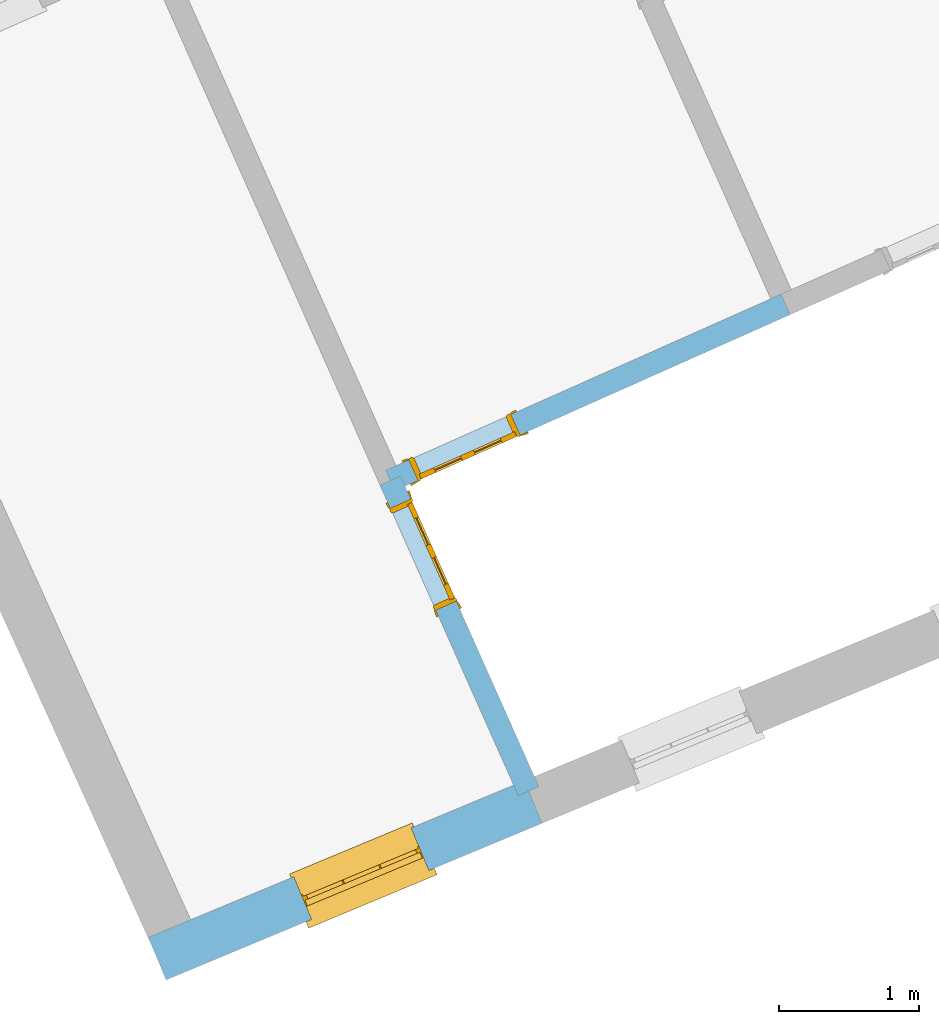
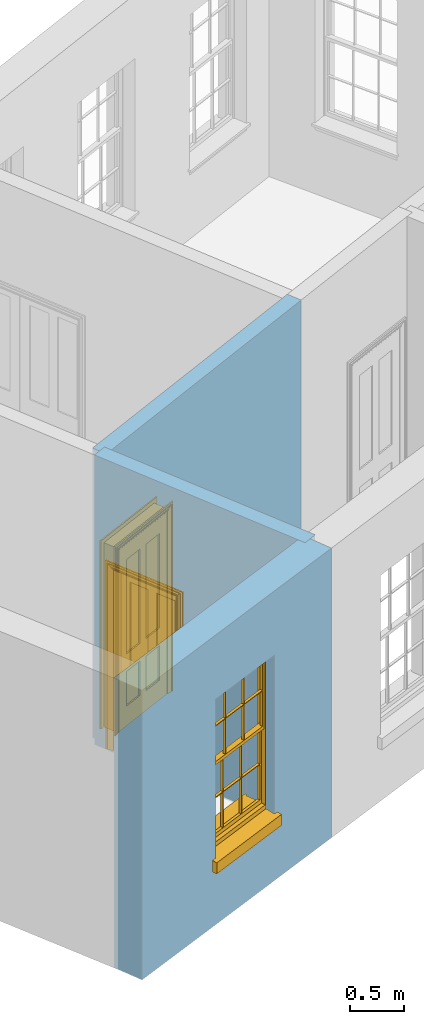
# One storey, part 2 of 8: 2 doors, 1 window, 3 openings, plus 3 elements that do not belong to this part.
"""IFC2X3 building model written with IfcOpenShell, lengths in metres."""

from ifc_helpers import new_model, si_unit, frame, origin, place, context, subcontext, project, spatial, polyline, outline, extrude, faceted_brep, material, layer, layer_set, layer_usage, element, fill, save


model = new_model("IFC2X3")

# Units and contexts
model_context = context("Model", 3, world=origin())
body_context = subcontext(model_context, "Body", "Model", "MODEL_VIEW")
ifc_project = project(units=[si_unit("PLANEANGLEUNIT", "RADIAN"), si_unit("MASSUNIT", "GRAM", prefix="KILO"), si_unit("FORCEUNIT", "NEWTON", prefix="KILO"), si_unit("LENGTHUNIT", "METRE")], contexts=[model_context])

# Site, building, storey
site_placement = place(None, origin())
site = spatial("IfcSite", under=ifc_project, at=site_placement, CompositionType="ELEMENT")
building_placement = place(None, origin())
building = spatial("IfcBuilding", under=site, at=building_placement, Name="Building plot-1", CompositionType="ELEMENT")
storey_placement = place(None, frame((0.0, 0.0, 5.15)))
storey = spatial("IfcBuildingStorey", under=building, at=storey_placement, Name="Floor 1", CompositionType="ELEMENT", Elevation=5.15)

# Wall, opening, window
ifc_material_1 = material(Name="Masonry")
ifc_layer_1 = layer(ifc_material_1, 0.33, ventilated=False)
ifc_layer_set_1 = layer_set([ifc_layer_1], Name="My Wall")
ifc_layer_usage_1 = layer_usage(ifc_layer_set_1, "AXIS2", "NEGATIVE", 0.08)
wall_1_placement = place(storey_placement, origin())
wall_1 = element("IfcWallStandardCase", 1, at=wall_1_placement, inside=storey, material=ifc_layer_usage_1, Name="exterior", context=body_context, shape_type="SweptSolid", body=[
    extrude(outline(polyline([(21.5557040167118, 40.2736905266135), (21.6826157364214, 39.9690704100743), (24.3699915253352, 41.0886927342715), (24.2430798056257, 41.3933128508107), (21.5557040167118, 40.2736905266135)])), origin(), (0.0, 0.0, 1.0), 3.3),
])
opening_1_placement = place(storey_placement, frame((0.0, 0.0, 0.75)))
opening_1 = element("IfcOpeningElement", 2, at=opening_1_placement, cuts=wall_1, Name="Opening", ObjectType="Opening", context=body_context, shape_type="SweptSolid", body=[
    extrude(outline(polyline([(22.7216835143391, 40.4019698524633), (23.5616965629775, 40.7519385340866), (23.434784843268, 41.0565586506259), (22.5947717946295, 40.7065899690026), (22.7216835143391, 40.4019698524633)])), origin(), (0.0, 0.0, 1.0), 1.82),
])
window_placement = place(storey_placement, frame((22.6255382721349, 40.6327426680233, 0.75), z_axis=(0.0, 0.0, 1.0), x_axis=(0.840013048638443, 0.349968681623302, 0.0)))
window = element("IfcWindow", 3, at=window_placement, inside=storey, Name="bedroom outside window", OverallHeight=1.82, OverallWidth=0.91, context=body_context, shape_type="Brep", held_by="IfcProductRepresentation", body=[
    faceted_brep([(0.033125, -0.105, 0.975209), (0.01, -0.105, 0.975209), (0.033125, -0.105, 1.376042), (0.876875, -0.105, 0.975209), (0.876875, -0.105, 1.376042), (0.9, -0.105, 0.975209), (0.876875, -0.105, 1.386042), (0.876875, -0.105, 1.786875), (0.9, -0.105, 1.81), (0.033125, -0.105, 1.786875), (0.033125, -0.105, 1.386042), (0.01, -0.105, 1.81), (0.876875, -0.135, 1.376042), (0.876875, -0.135, 0.975209), (0.9, -0.135, 0.937083), (0.033125, -0.135, 1.786875), (0.01, -0.135, 1.81), (0.033125, -0.135, 1.386042), (0.01, -0.135, 0.937083), (0.033125, -0.135, 0.975209), (0.033125, -0.135, 1.376042), (0.876875, -0.135, 1.786875), (0.876875, -0.135, 1.386042), (0.9, -0.135, 1.81), (0.033125, -0.105, 0.937083), (0.01, -0.105, 0.937083), (0.033125, -0.105, 0.53625), (0.876875, -0.105, 0.937083), (0.876875, -0.105, 0.53625), (0.9, -0.105, 0.937083), (0.876875, -0.105, 0.52625), (0.876875, -0.105, 0.125417), (0.9, -0.105, 0.077167), (0.033125, -0.105, 0.125417), (0.033125, -0.105, 0.52625), (0.01, -0.105, 0.077167), (-0.0425, -0.25, 0.01), (-0.0425, -0.3, 0.001667), (0.0, -0.25, 0.01), (0.9525, -0.25, 0.01), (0.91, -0.25, 0.01), (0.9525, -0.3, 0.001667), (-0.02, 0.08, 0.077167), (0.0, 0.08, 0.077167), (-0.02, 0.11, 0.077167), (0.0, -0.06, 0.077167), (0.01, -0.06, 0.077167), (0.91, -0.06, 0.077167), (0.91, 0.08, 0.077167), (0.9, -0.06, 0.077167), (0.93, 0.08, 0.077167), (0.93, 0.11, 0.077167), (0.01, -0.075, 0.975209), (0.9, -0.075, 0.975209), (0.876875, -0.075, 0.125417), (0.876875, -0.075, 0.52625), (0.9, -0.075, 0.077167), (0.876875, -0.075, 0.53625), (0.876875, -0.075, 0.937083), (0.033125, -0.075, 0.125417), (0.01, -0.075, 0.077167), (0.033125, -0.075, 0.52625), (0.033125, -0.075, 0.937083), (0.033125, -0.075, 0.53625), (-0.02, 0.08, 0.052167), (-0.02, 0.11, 0.052167), (0.93, 0.11, 0.052167), (0.93, 0.08, 0.052167), (0.91, 0.08, 0.052167), (0.0, 0.08, 0.052167), (0.91, -0.15, 0.026667), (0.0, -0.15, 0.026667), (-0.0425, -0.3, -0.123333), (0.9525, -0.3, -0.123333), (-0.0425, -0.25, -0.123333), (0.9525, -0.25, -0.123333), (0.01, -0.06, 1.81), (0.9, -0.06, 1.81), (0.0, -0.06, 1.82), (0.91, -0.06, 1.82), (0.01, -0.15, 0.077167), (0.9, -0.15, 0.077167), (0.592292, -0.105, 0.125417), (0.592292, -0.075, 0.125417), (0.317708, -0.075, 0.125417), (0.317708, -0.105, 0.125417), (0.592292, -0.105, 0.53625), (0.317708, -0.105, 0.53625), (0.317708, -0.105, 0.52625), (0.592292, -0.105, 0.52625), (0.592292, -0.075, 0.53625), (0.317708, -0.075, 0.53625), (0.592292, -0.135, 1.386042), (0.592292, -0.105, 1.386042), (0.317708, -0.105, 1.386042), (0.317708, -0.135, 1.386042), (0.317708, -0.135, 1.376042), (0.592292, -0.135, 1.376042), (0.317708, -0.105, 1.376042), (0.592292, -0.105, 1.376042), (0.602292, -0.135, 1.376042), (0.592292, -0.135, 0.975209), (0.602292, -0.135, 0.975209), (0.602292, -0.105, 0.975209), (0.592292, -0.105, 0.975209), (0.602292, -0.105, 1.376042), (0.602292, -0.075, 0.53625), (0.602292, -0.105, 0.53625), (0.317708, -0.075, 0.52625), (0.307708, -0.075, 0.125417), (0.307708, -0.075, 0.52625), (0.602292, -0.075, 0.52625), (0.602292, -0.075, 0.125417), (0.592292, -0.075, 0.52625), (0.307708, -0.075, 0.53625), (0.317708, -0.075, 0.937083), (0.307708, -0.075, 0.937083), (0.602292, -0.075, 0.937083), (0.592292, -0.075, 0.937083), (0.307708, -0.105, 0.52625), (0.307708, -0.105, 0.125417), (0.307708, -0.105, 0.53625), (0.307708, -0.105, 0.937083), (0.592292, -0.105, 0.937083), (0.317708, -0.105, 0.937083), (0.602292, -0.105, 0.937083), (0.602292, -0.105, 0.52625), (0.602292, -0.105, 0.125417), (0.307708, -0.135, 1.386042), (0.307708, -0.135, 1.376042), (0.307708, -0.135, 0.975209), (0.317708, -0.135, 0.975209), (0.317708, -0.135, 1.786875), (0.307708, -0.135, 1.786875), (0.602292, -0.135, 1.786875), (0.592292, -0.135, 1.786875), (0.602292, -0.135, 1.386042), (0.602292, -0.105, 1.386042), (0.307708, -0.105, 1.386042), (0.307708, -0.105, 1.786875), (0.317708, -0.105, 1.786875), (0.592292, -0.105, 1.786875), (0.602292, -0.105, 1.786875), (0.307708, -0.105, 1.376042), (0.317708, -0.105, 0.975209), (0.307708, -0.105, 0.975209), (0.91, -0.15, 1.82), (0.9, -0.15, 1.81), (0.01, -0.15, 1.81), (0.0, -0.15, 1.82), (0.91, -0.25, 0.0), (0.0, -0.25, 0.0), (0.91, 0.08, 0.0), (0.0, 0.08, 0.0)], [[[0, 1, 2]], [[3, 4, 5]], [[6, 7, 8]], [[9, 10, 11]], [[12, 13, 14]], [[15, 16, 17]], [[18, 19, 20]], [[21, 22, 23]], [[24, 25, 26]], [[27, 28, 29]], [[30, 31, 32]], [[33, 34, 35]], [[14, 27, 29]], [[25, 24, 18]], [[36, 37, 38]], [[39, 40, 41]], [[42, 43, 44]], [[45, 46, 43]], [[47, 48, 49]], [[50, 51, 48]], [[1, 0, 52]], [[5, 53, 3]], [[54, 55, 56]], [[57, 58, 53]], [[59, 60, 61]], [[62, 63, 52]], [[48, 43, 46, 49]], [[51, 44, 43, 48]], [[64, 42, 44, 65]], [[65, 44, 51, 66]], [[66, 51, 50, 67]], [[65, 66, 68, 69]], [[60, 56, 49, 46]], [[70, 71, 38, 40]], [[37, 41, 40, 38]], [[37, 72, 73, 41]], [[74, 75, 73, 72]], [[8, 11, 76, 77]], [[76, 78, 79, 77]], [[32, 35, 80, 81]], [[81, 80, 71, 70]], [[82, 83, 84, 85]], [[86, 87, 88, 89]], [[86, 90, 91, 87]], [[92, 93, 94, 95]], [[92, 95, 96, 97]], [[96, 98, 99, 97]], [[100, 97, 101, 102]], [[103, 104, 99, 105]], [[97, 99, 104, 101]], [[102, 103, 105, 100]], [[28, 57, 106, 107]], [[108, 84, 109, 110]], [[111, 112, 83, 113]], [[114, 110, 61, 63]], [[90, 113, 108, 91]], [[115, 91, 114, 116]], [[117, 106, 90, 118]], [[111, 106, 57, 55]], [[119, 110, 109, 120]], [[34, 61, 110, 119]], [[89, 113, 83, 82]], [[88, 108, 113, 89]], [[85, 84, 108, 88]], [[121, 114, 63, 26]], [[122, 116, 114, 121]], [[123, 118, 90, 86]], [[87, 91, 115, 124]], [[107, 106, 117, 125]], [[126, 111, 55, 30]], [[127, 112, 111, 126]], [[126, 30, 28, 107]], [[88, 119, 120, 85]], [[126, 89, 82, 127]], [[125, 123, 86, 107]], [[121, 26, 34, 119]], [[124, 122, 121, 87]], [[128, 17, 20, 129]], [[96, 129, 130, 131]], [[132, 133, 128, 95]], [[134, 135, 92, 136]], [[100, 12, 22, 136]], [[137, 6, 4, 105]], [[94, 138, 139, 140]], [[137, 93, 141, 142]], [[99, 98, 94, 93]], [[143, 2, 10, 138]], [[144, 145, 143, 98]], [[129, 143, 145, 130]], [[20, 2, 143, 129]], [[131, 144, 98, 96]], [[128, 138, 10, 17]], [[133, 139, 138, 128]], [[135, 141, 93, 92]], [[95, 94, 140, 132]], [[22, 6, 137, 136]], [[136, 137, 142, 134]], [[100, 105, 4, 12]], [[107, 86, 89, 126]], [[106, 111, 113, 90]], [[91, 108, 110, 114]], [[87, 121, 119, 88]], [[97, 100, 136, 92]], [[129, 96, 95, 128]], [[98, 143, 138, 94]], [[105, 99, 93, 137]], [[131, 101, 104, 144]], [[124, 115, 118, 123]], [[132, 140, 141, 135]], [[120, 109, 59, 33]], [[15, 9, 139, 133]], [[134, 142, 7, 21]], [[31, 54, 112, 127]], [[36, 74, 72, 37]], [[39, 41, 73, 75]], [[18, 14, 101, 131]], [[23, 16, 132, 135]], [[83, 56, 60, 84]], [[52, 53, 118, 115]], [[53, 52, 144, 104]], [[11, 8, 141, 140]], [[14, 18, 124, 123]], [[2, 1, 11, 10]], [[8, 5, 4, 6]], [[57, 53, 56, 55]], [[60, 52, 63, 61]], [[26, 25, 35, 34]], [[32, 29, 28, 30]], [[14, 23, 22, 12]], [[18, 20, 17, 16]], [[19, 0, 2, 20]], [[17, 10, 9, 15]], [[12, 4, 3, 13]], [[21, 7, 6, 22]], [[27, 58, 57, 28]], [[30, 55, 54, 31]], [[33, 59, 61, 34]], [[26, 63, 62, 24]], [[5, 8, 77, 53]], [[76, 11, 1, 52]], [[46, 45, 78, 76]], [[49, 77, 79, 47]], [[70, 146, 147, 81]], [[71, 80, 148, 149]], [[19, 130, 145, 0]], [[102, 13, 3, 103]], [[116, 122, 24, 62]], [[29, 32, 81, 14]], [[80, 35, 25, 18]], [[60, 46, 76, 52]], [[77, 49, 56, 53]], [[23, 14, 81, 147]], [[16, 148, 80, 18]], [[35, 85, 120]], [[120, 33, 35]], [[127, 82, 32]], [[32, 31, 127]], [[32, 82, 85, 35]], [[102, 101, 14]], [[14, 13, 102]], [[18, 131, 130]], [[130, 19, 18]], [[134, 21, 23]], [[23, 135, 134]], [[16, 15, 133]], [[133, 132, 16]], [[11, 140, 139]], [[139, 9, 11]], [[142, 141, 8]], [[8, 7, 142]], [[23, 147, 148, 16]], [[146, 149, 148, 147]], [[52, 115, 116]], [[116, 62, 52]], [[118, 53, 117]], [[58, 117, 53]], [[27, 125, 117, 58]], [[56, 83, 112]], [[112, 54, 56]], [[109, 84, 60]], [[60, 59, 109]], [[125, 27, 14]], [[14, 123, 125]], [[122, 124, 18]], [[18, 24, 122]], [[145, 144, 52]], [[52, 0, 145]], [[103, 3, 53]], [[53, 104, 103]], [[79, 78, 149, 146]], [[78, 45, 71, 149]], [[146, 70, 47, 79]], [[150, 75, 74, 151]], [[68, 66, 67]], [[48, 68, 67, 50]], [[69, 64, 65]], [[42, 64, 69, 43]], [[69, 68, 152, 153]], [[70, 68, 48, 47]], [[150, 152, 68, 70]], [[43, 69, 71, 45]], [[69, 153, 151, 71]], [[152, 150, 151, 153]], [[38, 151, 74, 36]], [[71, 151, 38]], [[39, 75, 150, 40]], [[40, 150, 70]]]),
])
fill(opening_1, window)

# Wall, opening, door
ifc_material_2 = material(Name="Masonry")
ifc_layer_2 = layer(ifc_material_2, 0.16, ventilated=False)
ifc_layer_set_2 = layer_set([ifc_layer_2], Name="My Wall")
ifc_layer_usage_2 = layer_usage(ifc_layer_set_2, "AXIS2", "NEGATIVE", 0.08)
wall_2_placement = place(storey_placement, origin())
wall_2 = element("IfcWallStandardCase", 4, at=wall_2_placement, inside=storey, material=ifc_layer_usage_2, Name="interior", context=body_context, shape_type="SweptSolid", body=[
    extrude(outline(polyline([(23.3583541885495, 43.5717500398352), (23.2121937993953, 43.5066567172722), (24.2007660885539, 41.28691888855), (24.3469264777081, 41.352012211113), (23.3583541885495, 43.5717500398352)])), origin(), (0.0, 0.0, 1.0), 3.3),
])
opening_2_placement = place(storey_placement, frame((0.0, 0.0, 0.0199999999999996)))
opening_2 = element("IfcOpeningElement", 5, at=opening_2_placement, cuts=wall_2, Name="Opening", ObjectType="Opening", context=body_context, shape_type="SweptSolid", body=[
    extrude(outline(polyline([(23.2854237872788, 43.3422262794737), (23.6108904000941, 42.6114243337028), (23.7570507892483, 42.6765176562659), (23.4315841764329, 43.4073196020368), (23.2854237872788, 43.3422262794737)])), origin(), (0.0, 0.0, 1.0), 2.1),
])
door_1_placement = place(storey_placement, frame((23.3585039818559, 43.3747729407552, 0.0199999999999996), z_axis=(0.0, 0.0, 1.0), x_axis=(0.325466612815337, -0.730801945770885, 0.0)))
door_1 = element("IfcDoor", 6, at=door_1_placement, inside=storey, Name="bedroom inside door", OverallHeight=2.1, OverallWidth=0.8, context=body_context, shape_type="Brep", held_by="IfcProductRepresentation", body=[
    faceted_brep([(0.773, 0.08, 1.895), (0.66, 0.08, 1.895), (0.66, 0.08, 2.073), (0.773, 0.08, 2.073), (0.773, 0.08, 0.82), (0.66, 0.08, 0.82), (0.45, 0.08, 1.895), (0.45, 0.08, 2.073), (0.773, 0.08, 0.62), (0.66, 0.08, 0.62), (0.66, 0.065, 0.82), (0.66, 0.065, 1.895), (0.45, 0.065, 1.895), (0.35, 0.08, 1.895), (0.35, 0.08, 2.073), (0.773, 0.08, 0.225), (0.66, 0.08, 0.225), (0.45, 0.08, 0.62), (0.45, 0.08, 0.82), (0.45, 0.065, 0.82), (0.35, 0.08, 0.82), (0.14, 0.08, 2.073), (0.14, 0.08, 1.895), (0.773, 0.08, 0.0), (0.66, 0.08, 0.0), (0.66, 0.065, 0.225), (0.66, 0.065, 0.62), (0.45, 0.065, 0.62), (0.35, 0.08, 0.62), (0.35, 0.065, 0.82), (0.35, 0.065, 1.895), (0.14, 0.065, 1.895), (0.027, 0.08, 2.073), (0.027, 0.08, 1.895), (0.773, 0.042, 0.0), (0.66, 0.042, 0.0), (0.45, 0.08, 0.0), (0.45, 0.08, 0.225), (0.45, 0.065, 0.225), (0.35, 0.08, 0.225), (0.14, 0.08, 0.82), (0.14, 0.08, 0.62), (0.14, 0.065, 0.82), (0.027, 0.08, 0.82), (0.773, 0.042, 0.225), (0.66, 0.042, 0.225), (0.45, 0.042, 0.0), (0.35, 0.08, 0.0), (0.35, 0.065, 0.225), (0.35, 0.065, 0.62), (0.14, 0.065, 0.62), (0.027, 0.08, 0.62), (0.773, 0.042, 0.62), (0.66, 0.042, 0.62), (0.45, 0.042, 0.225), (0.35, 0.042, 0.0), (0.14, 0.08, 0.225), (0.14, 0.08, 0.0), (0.14, 0.065, 0.225), (0.027, 0.08, 0.225), (0.773, 0.042, 0.82), (0.66, 0.042, 0.82), (0.66, 0.057, 0.62), (0.66, 0.057, 0.225), (0.45, 0.057, 0.225), (0.35, 0.042, 0.225), (0.14, 0.042, 0.0), (0.027, 0.08, 0.0), (0.773, 0.042, 1.895), (0.66, 0.042, 1.895), (0.45, 0.042, 0.62), (0.45, 0.042, 0.82), (0.45, 0.057, 0.62), (0.35, 0.042, 0.62), (0.14, 0.042, 0.225), (0.027, 0.042, 0.0), (0.773, 0.042, 2.073), (0.66, 0.042, 2.073), (0.66, 0.057, 1.895), (0.66, 0.057, 0.82), (0.45, 0.057, 0.82), (0.35, 0.042, 0.82), (0.35, 0.057, 0.62), (0.35, 0.057, 0.225), (0.14, 0.057, 0.225), (0.027, 0.042, 0.225), (0.45, 0.042, 1.895), (0.45, 0.042, 2.073), (0.45, 0.057, 1.895), (0.35, 0.042, 1.895), (0.14, 0.042, 0.82), (0.14, 0.042, 0.62), (0.14, 0.057, 0.62), (0.027, 0.042, 0.62), (0.35, 0.042, 2.073), (0.35, 0.057, 1.895), (0.35, 0.057, 0.82), (0.14, 0.057, 0.82), (0.027, 0.042, 0.82), (0.14, 0.042, 2.073), (0.14, 0.042, 1.895), (0.14, 0.057, 1.895), (0.027, 0.042, 1.895), (0.027, 0.042, 2.073), (0.02, 0.085, 0.0), (0.005, 0.09, 0.0), (0.005, 0.09, 2.095), (0.02, 0.085, 2.08), (0.02, 0.08, 0.0), (0.0, 0.085, 0.0), (0.0, 0.085, 2.1), (0.795, 0.09, 2.095), (0.78, 0.085, 2.08), (0.02, 0.08, 2.08), (0.0, 0.08, 0.0), (-0.032, 0.095, 0.0), (-0.032, 0.095, 2.132), (0.8, 0.085, 2.1), (0.795, 0.09, 0.0), (0.78, 0.085, 0.0), (0.78, 0.08, 2.08), (0.04, 0.04, 0.0), (0.025, 0.04, 0.0), (0.025, 0.04, 2.075), (0.04, 0.04, 2.06), (-0.04, 0.09, 0.0), (-0.04, 0.09, 2.14), (0.832, 0.095, 2.132), (0.8, 0.085, 0.0), (0.78, 0.08, 0.0), (0.8, 0.08, 0.0), (0.86, 0.08, 0.0), (0.86, 0.08, 2.16), (0.8, 0.08, 2.1), (-0.06, 0.08, 2.16), (0.0, 0.08, 2.1), (-0.06, 0.08, 0.0), (-0.04, 0.095, 0.0), (-0.04, 0.095, 2.14), (0.84, 0.09, 2.14), (0.832, 0.095, 0.0), (0.84, 0.09, 0.0), (0.86, 0.095, 0.0), (0.86, 0.095, 2.16), (-0.06, 0.095, 2.16), (-0.06, 0.095, 0.0), (0.84, 0.095, 0.0), (0.84, 0.095, 2.14), (-0.025, -0.095, 0.0), (-0.025, -0.09, 0.0), (-0.025, -0.09, 2.125), (-0.025, -0.095, 2.125), (-0.017, -0.095, 0.0), (-0.017, -0.095, 2.117), (0.825, -0.09, 2.125), (0.825, -0.095, 2.125), (0.825, -0.095, 0.0), (0.845, -0.095, 0.0), (-0.045, -0.095, 2.145), (-0.045, -0.095, 0.0), (0.845, -0.095, 2.145), (0.015, -0.085, 0.0), (0.015, -0.085, 2.085), (0.817, -0.095, 2.117), (0.825, -0.09, 0.0), (0.845, -0.08, 0.0), (0.845, -0.08, 2.145), (-0.045, -0.08, 2.145), (-0.045, -0.08, 0.0), (0.02, -0.09, 0.0), (0.02, -0.09, 2.08), (0.785, -0.085, 2.085), (0.817, -0.095, 0.0), (0.8, -0.08, 0.0), (0.8, -0.08, 2.1), (0.0, -0.08, 2.1), (0.0, -0.08, 0.0), (0.035, -0.085, 0.0), (0.035, -0.085, 2.065), (0.78, -0.09, 2.08), (0.785, -0.085, 0.0), (0.775, 0.04, 2.075), (0.76, 0.04, 2.06), (0.035, -0.08, 2.065), (0.035, -0.08, 0.0), (0.765, -0.085, 2.065), (0.78, -0.09, 0.0), (0.765, -0.08, 0.0), (0.765, -0.08, 2.065), (0.765, -0.085, 0.0), (0.04, -0.08, 2.06), (0.04, -0.08, 0.0), (0.76, -0.08, 2.06), (0.76, -0.08, 0.0), (0.76, 0.04, 0.0), (0.775, 0.04, 0.0), (0.025, 0.08, 0.0), (0.025, 0.08, 2.075), (0.775, 0.08, 0.0), (0.775, 0.08, 2.075)], [[[0, 1, 2, 3]], [[1, 0, 4, 5]], [[1, 6, 7, 2]], [[8, 9, 5, 4]], [[1, 5, 10, 11]], [[6, 1, 11, 12]], [[6, 13, 14, 7]], [[15, 16, 9, 8]], [[9, 17, 18, 5]], [[5, 18, 19, 10]], [[10, 19, 12, 11]], [[18, 6, 12, 19]], [[18, 20, 13, 6]], [[21, 14, 13, 22]], [[23, 24, 16, 15]], [[9, 16, 25, 26]], [[17, 9, 26, 27]], [[17, 28, 20, 18]], [[13, 20, 29, 30]], [[22, 13, 30, 31]], [[32, 21, 22, 33]], [[34, 35, 24, 23]], [[24, 36, 37, 16]], [[16, 37, 38, 25]], [[25, 38, 27, 26]], [[37, 17, 27, 38]], [[37, 39, 28, 17]], [[40, 20, 28, 41]], [[20, 40, 42, 29]], [[31, 30, 29, 42]], [[40, 22, 31, 42]], [[33, 22, 40, 43]], [[35, 34, 44, 45]], [[35, 46, 36, 24]], [[36, 47, 39, 37]], [[28, 39, 48, 49]], [[41, 28, 49, 50]], [[43, 40, 41, 51]], [[45, 44, 52, 53]], [[46, 35, 45, 54]], [[46, 55, 47, 36]], [[56, 39, 47, 57]], [[39, 56, 58, 48]], [[50, 49, 48, 58]], [[56, 41, 50, 58]], [[51, 41, 56, 59]], [[53, 52, 60, 61]], [[45, 53, 62, 63]], [[54, 45, 63, 64]], [[55, 46, 54, 65]], [[55, 66, 57, 47]], [[59, 56, 57, 67]], [[61, 60, 68, 69]], [[70, 53, 61, 71]], [[53, 70, 72, 62]], [[72, 64, 63, 62]], [[70, 54, 64, 72]], [[65, 54, 70, 73]], [[65, 74, 66, 55]], [[67, 57, 66, 75]], [[69, 68, 76, 77]], [[61, 69, 78, 79]], [[71, 61, 79, 80]], [[73, 70, 71, 81]], [[65, 73, 82, 83]], [[74, 65, 83, 84]], [[74, 85, 75, 66]], [[86, 69, 77, 87]], [[69, 86, 88, 78]], [[88, 80, 79, 78]], [[86, 71, 80, 88]], [[81, 71, 86, 89]], [[73, 81, 90, 91]], [[73, 91, 92, 82]], [[83, 82, 92, 84]], [[91, 74, 84, 92]], [[91, 93, 85, 74]], [[89, 86, 87, 94]], [[81, 89, 95, 96]], [[90, 81, 96, 97]], [[90, 98, 93, 91]], [[94, 99, 100, 89]], [[89, 100, 101, 95]], [[101, 97, 96, 95]], [[100, 90, 97, 101]], [[100, 102, 98, 90]], [[99, 103, 102, 100]], [[32, 103, 99, 21]], [[102, 103, 32, 33]], [[98, 102, 33, 43]], [[21, 99, 94, 14]], [[94, 87, 7, 14]], [[7, 87, 77, 2]], [[76, 3, 2, 77]], [[43, 51, 93, 98]], [[51, 59, 85, 93]], [[67, 75, 85, 59]], [[34, 23, 15, 44]], [[44, 15, 8, 52]], [[52, 8, 4, 60]], [[0, 68, 60, 4]], [[0, 3, 76, 68]], [[104, 105, 106, 107]], [[104, 108, 109, 105]], [[105, 109, 110, 106]], [[107, 106, 111, 112]], [[107, 113, 108, 104]], [[114, 109, 108]], [[109, 115, 116, 110]], [[106, 110, 117, 111]], [[112, 111, 118, 119]], [[113, 107, 112, 120]], [[121, 122, 123, 124]], [[115, 109, 114, 125]], [[115, 125, 126, 116]], [[110, 116, 127, 117]], [[111, 117, 128, 118]], [[118, 128, 129, 119]], [[120, 112, 119, 129]], [[130, 129, 128]], [[130, 131, 132, 133]], [[133, 132, 134, 135]], [[135, 134, 136, 114]], [[136, 125, 114]], [[125, 137, 138, 126]], [[116, 126, 139, 127]], [[117, 127, 140, 128]], [[141, 130, 128, 140]], [[131, 130, 141]], [[131, 142, 143, 132]], [[132, 143, 144, 134]], [[134, 144, 145, 136]], [[137, 125, 136, 145]], [[143, 142, 146]], [[143, 146, 147]], [[137, 145, 144]], [[143, 147, 138]], [[138, 137, 144]], [[143, 138, 144]], [[126, 138, 147, 139]], [[127, 139, 141, 140]], [[142, 131, 141, 146]], [[139, 147, 146, 141]], [[148, 149, 150, 151]], [[149, 152, 153, 150]], [[151, 150, 154, 155]], [[155, 156, 157]], [[158, 159, 148]], [[158, 148, 151]], [[155, 157, 160]], [[158, 151, 155]], [[155, 160, 158]], [[152, 161, 162, 153]], [[150, 153, 163, 154]], [[155, 154, 164, 156]], [[156, 164, 165, 157]], [[157, 165, 166, 160]], [[160, 166, 167, 158]], [[158, 167, 168, 159]], [[161, 169, 170, 162]], [[153, 162, 171, 163]], [[154, 163, 172, 164]], [[165, 164, 173]], [[165, 173, 174, 166]], [[166, 174, 175, 167]], [[167, 175, 176, 168]], [[169, 177, 178, 170]], [[162, 170, 179, 171]], [[163, 171, 180, 172]], [[172, 180, 173, 164]], [[124, 123, 181, 182]], [[183, 178, 177, 184]], [[170, 178, 185, 179]], [[171, 179, 186, 180]], [[187, 173, 180]], [[185, 188, 187, 189]], [[188, 185, 178, 183]], [[179, 185, 189, 186]], [[189, 187, 180, 186]], [[190, 183, 184, 191]], [[192, 188, 183, 190]], [[191, 184, 122, 121]], [[124, 190, 191, 121]], [[193, 187, 188, 192]], [[182, 192, 190, 124]], [[184, 176, 122]], [[194, 195, 187, 193]], [[192, 182, 194, 193]], [[161, 176, 184]], [[114, 108, 122, 176]], [[173, 187, 195]], [[152, 149, 176, 161]], [[169, 161, 184, 177]], [[196, 122, 108]], [[176, 175, 135, 114]], [[173, 195, 129, 130]], [[176, 149, 168]], [[123, 122, 196, 197]], [[196, 108, 113, 197]], [[175, 174, 133, 135]], [[198, 129, 195]], [[133, 174, 173, 130]], [[159, 168, 149, 148]], [[181, 123, 197, 199]], [[197, 113, 120, 199]], [[199, 120, 129, 198]], [[195, 181, 199, 198]], [[195, 194, 182, 181]]]),
])
fill(opening_2, door_1)

wall_3_placement = place(storey_placement, origin())
wall_3 = element("IfcWallStandardCase", 7, at=wall_3_placement, inside=storey, material=ifc_layer_usage_2, Name="interior", context=body_context, shape_type="SweptSolid", body=[
    extrude(outline(polyline([(26.1430137461052, 44.7243382600993), (26.0779204235422, 44.8704986492535), (23.2527273326909, 43.6122835731308), (23.3178206552539, 43.4661231839766), (26.1430137461052, 44.7243382600993)])), origin(), (0.0, 0.0, 1.0), 3.3),
])
opening_3_placement = place(storey_placement, frame((0.0, 0.0, 0.0199999999999996)))
opening_3 = element("IfcOpeningElement", 8, at=opening_3_placement, cuts=wall_3, Name="Opening", ObjectType="Opening", context=body_context, shape_type="SweptSolid", body=[
    extrude(outline(polyline([(24.1479597162602, 44.0109801738296), (23.4171577704893, 43.6855135610142), (23.4822510930524, 43.5393531718601), (24.2130530388233, 43.8648197846754), (24.1479597162602, 44.0109801738296)])), origin(), (0.0, 0.0, 1.0), 2.1),
])
door_2_placement = place(storey_placement, frame((24.1805063775417, 43.9378999792525, 0.0199999999999996), z_axis=(0.0, 0.0, 1.0), x_axis=(-0.730801945770875, -0.325466612815354, 0.0)))
door_2 = element("IfcDoor", 9, at=door_2_placement, inside=storey, Name="kitchen inside door", OverallHeight=2.1, OverallWidth=0.8, context=body_context, shape_type="Brep", held_by="IfcProductRepresentation", body=[
    faceted_brep([(0.773, 0.08, 1.895), (0.66, 0.08, 1.895), (0.66, 0.08, 2.073), (0.773, 0.08, 2.073), (0.773, 0.08, 0.82), (0.66, 0.08, 0.82), (0.45, 0.08, 1.895), (0.45, 0.08, 2.073), (0.773, 0.08, 0.62), (0.66, 0.08, 0.62), (0.66, 0.065, 0.82), (0.66, 0.065, 1.895), (0.45, 0.065, 1.895), (0.35, 0.08, 1.895), (0.35, 0.08, 2.073), (0.773, 0.08, 0.225), (0.66, 0.08, 0.225), (0.45, 0.08, 0.62), (0.45, 0.08, 0.82), (0.45, 0.065, 0.82), (0.35, 0.08, 0.82), (0.14, 0.08, 2.073), (0.14, 0.08, 1.895), (0.773, 0.08, 0.0), (0.66, 0.08, 0.0), (0.66, 0.065, 0.225), (0.66, 0.065, 0.62), (0.45, 0.065, 0.62), (0.35, 0.08, 0.62), (0.35, 0.065, 0.82), (0.35, 0.065, 1.895), (0.14, 0.065, 1.895), (0.027, 0.08, 2.073), (0.027, 0.08, 1.895), (0.773, 0.042, 0.0), (0.66, 0.042, 0.0), (0.45, 0.08, 0.0), (0.45, 0.08, 0.225), (0.45, 0.065, 0.225), (0.35, 0.08, 0.225), (0.14, 0.08, 0.82), (0.14, 0.08, 0.62), (0.14, 0.065, 0.82), (0.027, 0.08, 0.82), (0.773, 0.042, 0.225), (0.66, 0.042, 0.225), (0.45, 0.042, 0.0), (0.35, 0.08, 0.0), (0.35, 0.065, 0.225), (0.35, 0.065, 0.62), (0.14, 0.065, 0.62), (0.027, 0.08, 0.62), (0.773, 0.042, 0.62), (0.66, 0.042, 0.62), (0.45, 0.042, 0.225), (0.35, 0.042, 0.0), (0.14, 0.08, 0.225), (0.14, 0.08, 0.0), (0.14, 0.065, 0.225), (0.027, 0.08, 0.225), (0.773, 0.042, 0.82), (0.66, 0.042, 0.82), (0.66, 0.057, 0.62), (0.66, 0.057, 0.225), (0.45, 0.057, 0.225), (0.35, 0.042, 0.225), (0.14, 0.042, 0.0), (0.027, 0.08, 0.0), (0.773, 0.042, 1.895), (0.66, 0.042, 1.895), (0.45, 0.042, 0.62), (0.45, 0.042, 0.82), (0.45, 0.057, 0.62), (0.35, 0.042, 0.62), (0.14, 0.042, 0.225), (0.027, 0.042, 0.0), (0.773, 0.042, 2.073), (0.66, 0.042, 2.073), (0.66, 0.057, 1.895), (0.66, 0.057, 0.82), (0.45, 0.057, 0.82), (0.35, 0.042, 0.82), (0.35, 0.057, 0.62), (0.35, 0.057, 0.225), (0.14, 0.057, 0.225), (0.027, 0.042, 0.225), (0.45, 0.042, 1.895), (0.45, 0.042, 2.073), (0.45, 0.057, 1.895), (0.35, 0.042, 1.895), (0.14, 0.042, 0.82), (0.14, 0.042, 0.62), (0.14, 0.057, 0.62), (0.027, 0.042, 0.62), (0.35, 0.042, 2.073), (0.35, 0.057, 1.895), (0.35, 0.057, 0.82), (0.14, 0.057, 0.82), (0.027, 0.042, 0.82), (0.14, 0.042, 2.073), (0.14, 0.042, 1.895), (0.14, 0.057, 1.895), (0.027, 0.042, 1.895), (0.027, 0.042, 2.073), (0.02, 0.085, 0.0), (0.005, 0.09, 0.0), (0.005, 0.09, 2.095), (0.02, 0.085, 2.08), (0.02, 0.08, 0.0), (0.0, 0.085, 0.0), (0.0, 0.085, 2.1), (0.795, 0.09, 2.095), (0.78, 0.085, 2.08), (0.02, 0.08, 2.08), (0.0, 0.08, 0.0), (-0.032, 0.095, 0.0), (-0.032, 0.095, 2.132), (0.8, 0.085, 2.1), (0.795, 0.09, 0.0), (0.78, 0.085, 0.0), (0.78, 0.08, 2.08), (0.04, 0.04, 0.0), (0.025, 0.04, 0.0), (0.025, 0.04, 2.075), (0.04, 0.04, 2.06), (-0.04, 0.09, 0.0), (-0.04, 0.09, 2.14), (0.832, 0.095, 2.132), (0.8, 0.085, 0.0), (0.78, 0.08, 0.0), (0.8, 0.08, 0.0), (0.86, 0.08, 0.0), (0.86, 0.08, 2.16), (0.8, 0.08, 2.1), (-0.06, 0.08, 2.16), (0.0, 0.08, 2.1), (-0.06, 0.08, 0.0), (-0.04, 0.095, 0.0), (-0.04, 0.095, 2.14), (0.84, 0.09, 2.14), (0.832, 0.095, 0.0), (0.84, 0.09, 0.0), (0.86, 0.095, 0.0), (0.86, 0.095, 2.16), (-0.06, 0.095, 2.16), (-0.06, 0.095, 0.0), (0.84, 0.095, 0.0), (0.84, 0.095, 2.14), (-0.025, -0.095, 0.0), (-0.025, -0.09, 0.0), (-0.025, -0.09, 2.125), (-0.025, -0.095, 2.125), (-0.017, -0.095, 0.0), (-0.017, -0.095, 2.117), (0.825, -0.09, 2.125), (0.825, -0.095, 2.125), (0.825, -0.095, 0.0), (0.845, -0.095, 0.0), (-0.045, -0.095, 2.145), (-0.045, -0.095, 0.0), (0.845, -0.095, 2.145), (0.015, -0.085, 0.0), (0.015, -0.085, 2.085), (0.817, -0.095, 2.117), (0.825, -0.09, 0.0), (0.845, -0.08, 0.0), (0.845, -0.08, 2.145), (-0.045, -0.08, 2.145), (-0.045, -0.08, 0.0), (0.02, -0.09, 0.0), (0.02, -0.09, 2.08), (0.785, -0.085, 2.085), (0.817, -0.095, 0.0), (0.8, -0.08, 0.0), (0.8, -0.08, 2.1), (0.0, -0.08, 2.1), (0.0, -0.08, 0.0), (0.035, -0.085, 0.0), (0.035, -0.085, 2.065), (0.78, -0.09, 2.08), (0.785, -0.085, 0.0), (0.775, 0.04, 2.075), (0.76, 0.04, 2.06), (0.035, -0.08, 2.065), (0.035, -0.08, 0.0), (0.765, -0.085, 2.065), (0.78, -0.09, 0.0), (0.765, -0.08, 0.0), (0.765, -0.08, 2.065), (0.765, -0.085, 0.0), (0.04, -0.08, 2.06), (0.04, -0.08, 0.0), (0.76, -0.08, 2.06), (0.76, -0.08, 0.0), (0.76, 0.04, 0.0), (0.775, 0.04, 0.0), (0.025, 0.08, 0.0), (0.025, 0.08, 2.075), (0.775, 0.08, 0.0), (0.775, 0.08, 2.075)], [[[0, 1, 2, 3]], [[1, 0, 4, 5]], [[1, 6, 7, 2]], [[8, 9, 5, 4]], [[1, 5, 10, 11]], [[6, 1, 11, 12]], [[6, 13, 14, 7]], [[15, 16, 9, 8]], [[9, 17, 18, 5]], [[5, 18, 19, 10]], [[10, 19, 12, 11]], [[18, 6, 12, 19]], [[18, 20, 13, 6]], [[21, 14, 13, 22]], [[23, 24, 16, 15]], [[9, 16, 25, 26]], [[17, 9, 26, 27]], [[17, 28, 20, 18]], [[13, 20, 29, 30]], [[22, 13, 30, 31]], [[32, 21, 22, 33]], [[34, 35, 24, 23]], [[24, 36, 37, 16]], [[16, 37, 38, 25]], [[25, 38, 27, 26]], [[37, 17, 27, 38]], [[37, 39, 28, 17]], [[40, 20, 28, 41]], [[20, 40, 42, 29]], [[31, 30, 29, 42]], [[40, 22, 31, 42]], [[33, 22, 40, 43]], [[35, 34, 44, 45]], [[35, 46, 36, 24]], [[36, 47, 39, 37]], [[28, 39, 48, 49]], [[41, 28, 49, 50]], [[43, 40, 41, 51]], [[45, 44, 52, 53]], [[46, 35, 45, 54]], [[46, 55, 47, 36]], [[56, 39, 47, 57]], [[39, 56, 58, 48]], [[50, 49, 48, 58]], [[56, 41, 50, 58]], [[51, 41, 56, 59]], [[53, 52, 60, 61]], [[45, 53, 62, 63]], [[54, 45, 63, 64]], [[55, 46, 54, 65]], [[55, 66, 57, 47]], [[59, 56, 57, 67]], [[61, 60, 68, 69]], [[70, 53, 61, 71]], [[53, 70, 72, 62]], [[72, 64, 63, 62]], [[70, 54, 64, 72]], [[65, 54, 70, 73]], [[65, 74, 66, 55]], [[67, 57, 66, 75]], [[69, 68, 76, 77]], [[61, 69, 78, 79]], [[71, 61, 79, 80]], [[73, 70, 71, 81]], [[65, 73, 82, 83]], [[74, 65, 83, 84]], [[74, 85, 75, 66]], [[86, 69, 77, 87]], [[69, 86, 88, 78]], [[88, 80, 79, 78]], [[86, 71, 80, 88]], [[81, 71, 86, 89]], [[73, 81, 90, 91]], [[73, 91, 92, 82]], [[83, 82, 92, 84]], [[91, 74, 84, 92]], [[91, 93, 85, 74]], [[89, 86, 87, 94]], [[81, 89, 95, 96]], [[90, 81, 96, 97]], [[90, 98, 93, 91]], [[94, 99, 100, 89]], [[89, 100, 101, 95]], [[101, 97, 96, 95]], [[100, 90, 97, 101]], [[100, 102, 98, 90]], [[99, 103, 102, 100]], [[32, 103, 99, 21]], [[102, 103, 32, 33]], [[98, 102, 33, 43]], [[21, 99, 94, 14]], [[94, 87, 7, 14]], [[7, 87, 77, 2]], [[76, 3, 2, 77]], [[43, 51, 93, 98]], [[51, 59, 85, 93]], [[67, 75, 85, 59]], [[34, 23, 15, 44]], [[44, 15, 8, 52]], [[52, 8, 4, 60]], [[0, 68, 60, 4]], [[0, 3, 76, 68]], [[104, 105, 106, 107]], [[104, 108, 109, 105]], [[105, 109, 110, 106]], [[107, 106, 111, 112]], [[107, 113, 108, 104]], [[114, 109, 108]], [[109, 115, 116, 110]], [[106, 110, 117, 111]], [[112, 111, 118, 119]], [[113, 107, 112, 120]], [[121, 122, 123, 124]], [[115, 109, 114, 125]], [[115, 125, 126, 116]], [[110, 116, 127, 117]], [[111, 117, 128, 118]], [[118, 128, 129, 119]], [[120, 112, 119, 129]], [[130, 129, 128]], [[130, 131, 132, 133]], [[133, 132, 134, 135]], [[135, 134, 136, 114]], [[136, 125, 114]], [[125, 137, 138, 126]], [[116, 126, 139, 127]], [[117, 127, 140, 128]], [[141, 130, 128, 140]], [[131, 130, 141]], [[131, 142, 143, 132]], [[132, 143, 144, 134]], [[134, 144, 145, 136]], [[137, 125, 136, 145]], [[143, 142, 146]], [[143, 146, 147]], [[137, 145, 144]], [[143, 147, 138]], [[138, 137, 144]], [[143, 138, 144]], [[126, 138, 147, 139]], [[127, 139, 141, 140]], [[142, 131, 141, 146]], [[139, 147, 146, 141]], [[148, 149, 150, 151]], [[149, 152, 153, 150]], [[151, 150, 154, 155]], [[155, 156, 157]], [[158, 159, 148]], [[158, 148, 151]], [[155, 157, 160]], [[158, 151, 155]], [[155, 160, 158]], [[152, 161, 162, 153]], [[150, 153, 163, 154]], [[155, 154, 164, 156]], [[156, 164, 165, 157]], [[157, 165, 166, 160]], [[160, 166, 167, 158]], [[158, 167, 168, 159]], [[161, 169, 170, 162]], [[153, 162, 171, 163]], [[154, 163, 172, 164]], [[165, 164, 173]], [[165, 173, 174, 166]], [[166, 174, 175, 167]], [[167, 175, 176, 168]], [[169, 177, 178, 170]], [[162, 170, 179, 171]], [[163, 171, 180, 172]], [[172, 180, 173, 164]], [[124, 123, 181, 182]], [[183, 178, 177, 184]], [[170, 178, 185, 179]], [[171, 179, 186, 180]], [[187, 173, 180]], [[185, 188, 187, 189]], [[188, 185, 178, 183]], [[179, 185, 189, 186]], [[189, 187, 180, 186]], [[190, 183, 184, 191]], [[192, 188, 183, 190]], [[191, 184, 122, 121]], [[124, 190, 191, 121]], [[193, 187, 188, 192]], [[182, 192, 190, 124]], [[184, 176, 122]], [[194, 195, 187, 193]], [[192, 182, 194, 193]], [[161, 176, 184]], [[114, 108, 122, 176]], [[173, 187, 195]], [[152, 149, 176, 161]], [[169, 161, 184, 177]], [[196, 122, 108]], [[176, 175, 135, 114]], [[173, 195, 129, 130]], [[176, 149, 168]], [[123, 122, 196, 197]], [[196, 108, 113, 197]], [[175, 174, 133, 135]], [[198, 129, 195]], [[133, 174, 173, 130]], [[159, 168, 149, 148]], [[181, 123, 197, 199]], [[197, 113, 120, 199]], [[199, 120, 129, 198]], [[195, 181, 199, 198]], [[195, 194, 182, 181]]]),
])
fill(opening_3, door_2)

save(model, "model.ifc")
